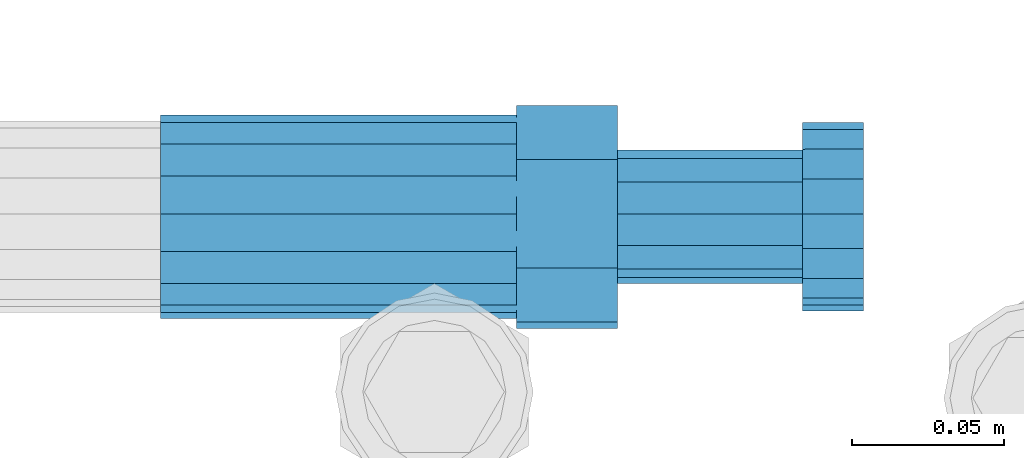
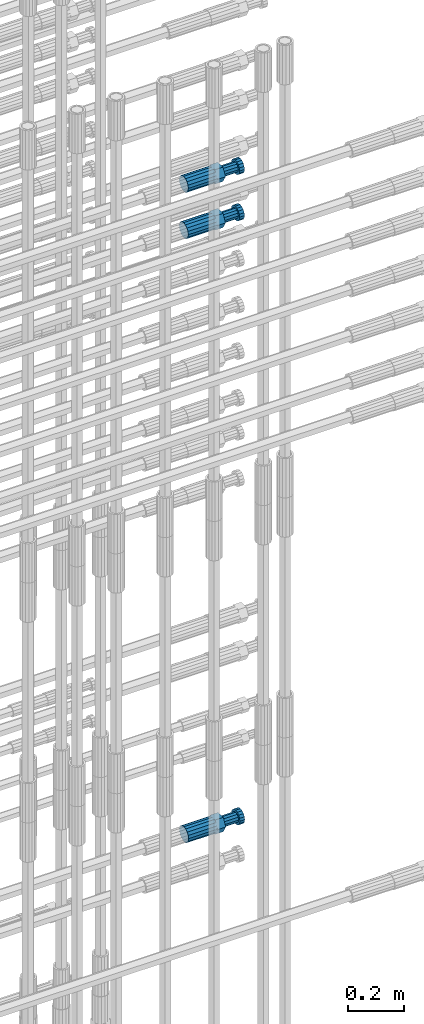
# One storey, part 99 of 119: 3 beams.
"""IFC2X3 building model written with IfcOpenShell, lengths in millimetres."""

from ifc_helpers import new_model, si_unit, frame, origin_with_axes, place, context, subcontext, project, spatial, faceted_brep, material, type_object, element, save


model = new_model("IFC2X3")

# Units and contexts
model_context = context("Model", 3, precision=1e-05, world=origin_with_axes())
body_context = subcontext(model_context, "Body", "Model", "MODEL_VIEW")
ifc_project = project(units=[si_unit("LENGTHUNIT", "METRE", prefix="MILLI"), si_unit("AREAUNIT", "SQUARE_METRE"), si_unit("VOLUMEUNIT", "CUBIC_METRE"), si_unit("MASSUNIT", "GRAM", prefix="KILO"), si_unit("TIMEUNIT", "SECOND"), si_unit("PLANEANGLEUNIT", "RADIAN"), si_unit("SOLIDANGLEUNIT", "STERADIAN"), si_unit("THERMODYNAMICTEMPERATUREUNIT", "DEGREE_CELSIUS"), si_unit("LUMINOUSINTENSITYUNIT", "LUMEN")], contexts=[model_context])

# Site, building, storey
site_placement = place(None, origin_with_axes())
site = spatial("IfcSite", under=ifc_project, at=site_placement, CompositionType="ELEMENT")
building_placement = place(site_placement, origin_with_axes())
building = spatial("IfcBuilding", under=site, at=building_placement, Name="Undefined", CompositionType="ELEMENT")
storey_placement = place(building_placement, origin_with_axes())
storey = spatial("IfcBuildingStorey", under=building, at=storey_placement, Name="Undefined", CompositionType="ELEMENT", Elevation=0.0)

# Beams
ifc_material = material(Name="STEEL/S275")
beam_type = type_object("IfcBeamType", Name="ROD65", PredefinedType="NOTDEFINED")
beam_1_placement = place(storey_placement, frame((2038738.98023304, 6205212.98994599, 19499.269421743), z_axis=(0.0, 0.0, 1.0), x_axis=(1.0, 0.0, 0.0)))
element("IfcBeam", 1, at=beam_1_placement, inside=storey, type_object=beam_type, material=ifc_material, Name="AGB40", ObjectType="ROD65", context=body_context, shape_type="Brep", body=[
    faceted_brep([(116.999999999069, 17.8249999252148, 30.8738056446964), (116.999999998137, 22.0056957420893, 23.632628078838), (116.999999999069, 12.4372115600854, 30.0260848066173), (116.999999999069, 8.17543111252598, 30.8738056446964), (117.000000000931, -17.8250000746921, 30.8738056446964), (150.200000001118, -17.8250000723638, 30.8738056446964), (150.199999999255, 17.8249999275431, 30.8738056446964), (117.000000000931, -8.17543109622784, 30.8738056446964), (117.000000001863, -22.0056959956419, 23.6326278985034), (117.000000000931, -12.4372115437873, 30.0260848066173), (117.000000001863, -35.6500000746455, -2.18278728425503e-10), (150.200000002049, -35.6500000723172, -2.18278728425503e-10), (117.000000001863, -30.8443149488885, 8.32369080289209), (117.000000001863, -30.8443149488885, -8.32369080355784), (117.000000002794, -32.4999999918509, 0.0), (117.000000000931, -17.8250000746921, -30.873805645133), (150.200000001118, -17.8250000723638, -30.873805645133), (117.000000001863, -22.0056959961075, -23.6326278982269), (117.000000000931, -8.17543109389953, -30.873805645133), (117.000000000931, -12.4372115437873, -30.0260848066173), (116.999999999069, 17.8249999252148, -30.873805645133), (150.199999999255, 17.8249999275431, -30.873805645133), (116.999999999069, 8.17543111019768, -30.873805645133), (116.999999999069, 12.4372115600854, -30.0260848066173), (116.999999998137, 22.005695742555, -23.6326280785652), (116.999999998137, 35.6499999251682, -2.18278728425503e-10), (150.199999998324, 35.6499999277294, -2.18278728425503e-10), (116.999999998137, 30.8443150522653, -8.32369036550881), (116.999999997206, 32.5000000081491, 0.0), (116.999999998137, 30.8443150522653, 8.32369036483942), (1.86264514923096e-09, -22.9809703885112, 22.9809703885621), (1.86264514923096e-09, -30.0260848065373, 12.4372115518672), (117.000000001863, -30.0260847983882, 12.4372115518672), (117.000000001863, -22.9809703803621, 22.9809703885621), (-1.86264514923096e-09, 22.9809703885112, -22.9809703885621), (-1.86264514923096e-09, 30.0260848065373, -12.4372115518672), (116.999999998137, 30.0260848146863, -12.4372115518672), (116.999999998137, 22.9809703966603, -22.9809703885621), (1.86264514923096e-09, -30.0260848065373, -12.4372115518672), (1.86264514923096e-09, -22.9809703885112, -22.9809703885621), (117.000000001863, -22.9809703803621, -22.9809703885621), (117.000000001863, -30.0260847983882, -12.4372115518672), (9.31322574615479e-10, -12.4372115519363, 30.0260848066173), (0.0, 0.0, 32.5), (-9.31322574615479e-10, 12.4372115519363, 30.0260848066173), (-1.86264514923096e-09, 22.9809703885112, 22.9809703885621), (-1.86264514923096e-09, 30.0260848065373, 12.4372115518672), (-2.79396772384644e-09, 32.5, 0.0), (-9.31322574615479e-10, 12.4372115519363, -30.0260848066173), (0.0, 0.0, -32.5), (9.31322574615479e-10, -12.4372115519363, -30.0260848066173), (2.79396772384644e-09, -32.5, 0.0), (116.999999998137, 22.9809703966603, 22.9809703885621), (116.999999998137, 30.0260848146863, 12.4372115518672), (117.0, 8.14907252788544e-09, -32.5), (117.0, 8.14907252788544e-09, 32.5), (150.200000000186, -10.5000000959262, 18.1865334791873), (150.199999999255, -9.59262251853943e-08, 20.9999999997126), (150.199999998324, 10.4999999040738, 18.1865334791873), (150.199999997392, 18.1865333835594, 10.4999999997126), (150.199999997392, 20.9999999040738, -2.87400325760245e-10), (150.199999997392, 18.1865333835594, -10.5000000002874), (150.199999998324, 10.4999999040738, -18.1865334797621), (150.199999999255, -9.59262251853943e-08, -21.0000000002874), (150.200000000186, -10.5000000959262, -18.1865334797621), (150.200000000186, -18.1865335754119, -10.5000000002874), (150.200000001118, -21.0000000959262, -2.87400325760245e-10), (150.200000000186, -18.1865335754119, 10.4999999997126), (210.979999999516, 10.4999999082647, 18.1865334791873), (210.979999999516, -9.17352735996246e-08, 20.9999999997126), (210.979999997653, 18.1865333877504, 10.4999999997126), (210.979999997653, 20.9999999082647, -2.87400325760245e-10), (210.979999997653, 18.1865333877504, -10.5000000002874), (210.979999999516, 10.4999999082647, -18.1865334797621), (210.979999999516, -9.17352735996246e-08, -21.0000000002874), (210.979999999516, -10.5000000917353, -18.1865334797621), (210.980000000447, -18.1865335712209, -10.5000000002874), (210.980000001378, -21.0000000917353, -2.87400325760245e-10), (210.980000000447, -18.1865335712209, 10.4999999997126), (210.979999999516, -10.5000000917353, 18.1865334791873), (211.001368402503, -27.7269939335529, -11.4911163272045), (211.003082515672, -21.2238095656503, -21.2238154190527), (231.002518340945, -21.2131946226582, -21.2132004554769), (231.000804228708, -27.7163789905608, -11.4805013636287), (211.001368415542, -11.4911086384673, -27.7269970399575), (231.000804241747, -11.4804936954752, -27.7163820763781), (210.996487061493, -0.0106066407170147, -30.0106107396168), (230.995922887698, 8.30227509140968e-06, -29.999995776041), (210.98918159306, 11.4698940692469, -27.7269970332745), (230.988617419265, 11.4805090120062, -27.7163820696951), (210.980564201251, 21.2025913291145, -21.2238154067054), (230.980000027455, 21.2132062721066, -21.2132004431296), (210.971946807578, 27.7057702087332, -11.4911163110701), (230.971382633783, 27.7163851517253, -11.4805013474943), (210.964641331695, 29.9893806746695, -0.0106149565435771), (230.9640771579, 29.9999956176616, 7.03221303410828e-09), (210.959759964608, 27.7057637346443, 11.4698863966551), (230.959195790812, 27.7163786776364, 11.4805013602345), (210.958045851439, 21.2025793667417, 21.2025854885032), (230.957481677644, 21.2131943097338, 21.2132004520827), (210.959759951569, 11.4698784395587, 27.705767109408), (230.959195776843, 11.4804933823179, 27.7163820729838), (210.964641305618, -0.0106235581915826, 29.9893808090674), (230.964077131823, -8.61519947648048e-06, 29.9999957726432), (210.971946774051, -11.4911242681555, 27.7057671027251), (230.971382599324, -11.4805093251634, 27.7163820663009), (210.98056416586, -21.2238215280231, 21.2025854761559), (230.979999991134, -21.2132065852638, 21.2132004397354), (210.989181559533, -27.7270004076418, 11.4698863805206), (230.988617384806, -27.7163854646496, 11.4805013441), (210.996487035416, -30.0106108735781, -0.0106149740058754), (230.995922861621, -29.999995930586, -1.04300852399319e-08)], [[[0, 1, 2, 3]], [[4, 5, 6, 0, 3, 7]], [[8, 4, 7, 9]], [[10, 11, 5, 4, 8, 12]], [[13, 10, 12, 14]], [[15, 16, 11, 10, 13, 17]], [[18, 15, 17, 19]], [[20, 21, 16, 15, 18, 22]], [[20, 22, 23, 24]], [[25, 26, 21, 20, 24, 27]], [[25, 27, 28, 29]], [[30, 31, 32, 33]], [[34, 35, 36, 37]], [[38, 39, 40, 41]], [[31, 30, 42, 43, 44, 45, 46, 47, 35, 34, 48, 49, 50, 39, 38, 51]], [[46, 45, 52, 53]], [[28, 47, 46, 53, 29]], [[27, 36, 35, 47, 28]], [[24, 37, 36, 27]], [[23, 48, 34, 37, 24]], [[22, 54, 49, 48, 23]], [[18, 54, 22]], [[19, 50, 49, 54, 18]], [[17, 40, 39, 50, 19]], [[13, 41, 40, 17]], [[14, 51, 38, 41, 13]], [[12, 32, 31, 51, 14]], [[8, 33, 32, 12]], [[9, 42, 30, 33, 8]], [[7, 55, 43, 42, 9]], [[3, 55, 7]], [[2, 44, 43, 55, 3]], [[1, 52, 45, 44, 2]], [[29, 53, 52, 1]], [[0, 6, 26, 25, 29, 1]], [[5, 11, 16, 21, 26, 6], [56, 57, 58, 59, 60, 61, 62, 63, 64, 65, 66, 67]], [[68, 58, 57, 69]], [[70, 59, 58, 68]], [[71, 60, 59, 70]], [[72, 61, 60, 71]], [[73, 62, 61, 72]], [[74, 63, 62, 73]], [[75, 64, 63, 74]], [[76, 65, 64, 75]], [[77, 66, 65, 76]], [[78, 67, 66, 77]], [[79, 56, 67, 78]], [[69, 57, 56, 79]], [[80, 81, 82, 83]], [[81, 84, 85, 82]], [[84, 86, 87, 85]], [[86, 88, 89, 87]], [[88, 90, 91, 89]], [[90, 92, 93, 91]], [[92, 94, 95, 93]], [[94, 96, 97, 95]], [[96, 98, 99, 97]], [[98, 100, 101, 99]], [[100, 102, 103, 101]], [[102, 104, 105, 103]], [[104, 106, 107, 105]], [[106, 108, 109, 107]], [[108, 110, 111, 109]], [[82, 85, 87, 89, 91, 93, 95, 97, 99, 101, 103, 105, 107, 109, 111, 83]], [[110, 80, 83, 111]], [[108, 106, 104, 102, 100, 98, 96, 94, 92, 90, 88, 86, 84, 81, 80, 110], [78, 77, 76, 75, 74, 73, 72, 71, 70, 68, 69, 79]]]),
])
beam_2_placement = place(storey_placement, frame((2038739.00023304, 6205214.98994599, 22308.9894219673), z_axis=(0.0, 0.0, 1.0), x_axis=(1.0, 0.0, 0.0)))
element("IfcBeam", 2, at=beam_2_placement, inside=storey, type_object=beam_type, material=ifc_material, Name="AGB40", ObjectType="ROD65", context=body_context, shape_type="Brep", body=[
    faceted_brep([(116.999999999069, 17.8249999252148, 30.8738056446964), (116.999999998137, 22.0056957420893, 23.632628078838), (116.999999999069, 12.4372115600854, 30.0260848066173), (116.999999999069, 8.17543111252598, 30.8738056446964), (117.000000000931, -17.8250000746921, 30.8738056446964), (150.200000001118, -17.8250000723638, 30.8738056446964), (150.199999999255, 17.8249999275431, 30.8738056446964), (117.000000000931, -8.17543109622784, 30.8738056446964), (117.000000001863, -22.0056959956419, 23.6326278985034), (117.000000000931, -12.4372115437873, 30.0260848066173), (117.000000001863, -35.6500000746455, -2.18278728425503e-10), (150.200000002049, -35.6500000723172, -2.18278728425503e-10), (117.000000001863, -30.8443149488885, 8.32369080289209), (117.000000001863, -30.8443149488885, -8.32369080355784), (117.000000002794, -32.4999999918509, 0.0), (117.000000000931, -17.8250000746921, -30.873805645133), (150.200000001118, -17.8250000723638, -30.873805645133), (117.000000001863, -22.0056959961075, -23.6326278982269), (117.000000000931, -8.17543109389953, -30.873805645133), (117.000000000931, -12.4372115437873, -30.0260848066173), (116.999999999069, 17.8249999252148, -30.873805645133), (150.199999999255, 17.8249999275431, -30.873805645133), (116.999999999069, 8.17543111019768, -30.873805645133), (116.999999999069, 12.4372115600854, -30.0260848066173), (116.999999998137, 22.005695742555, -23.6326280785652), (116.999999998137, 35.6499999251682, -2.18278728425503e-10), (150.199999998324, 35.6499999277294, -2.18278728425503e-10), (116.999999998137, 30.8443150522653, -8.32369036550881), (116.999999997206, 32.5000000081491, 0.0), (116.999999998137, 30.8443150522653, 8.32369036483942), (1.86264514923096e-09, -22.9809703885112, 22.9809703885621), (1.86264514923096e-09, -30.0260848065373, 12.4372115518672), (117.000000001863, -30.0260847983882, 12.4372115518672), (117.000000001863, -22.9809703803621, 22.9809703885621), (-1.86264514923096e-09, 22.9809703885112, -22.9809703885621), (-1.86264514923096e-09, 30.0260848065373, -12.4372115518672), (116.999999998137, 30.0260848146863, -12.4372115518672), (116.999999998137, 22.9809703966603, -22.9809703885621), (1.86264514923096e-09, -30.0260848065373, -12.4372115518672), (1.86264514923096e-09, -22.9809703885112, -22.9809703885621), (117.000000001863, -22.9809703803621, -22.9809703885621), (117.000000001863, -30.0260847983882, -12.4372115518672), (9.31322574615479e-10, -12.4372115519363, 30.0260848066173), (0.0, 0.0, 32.5), (-9.31322574615479e-10, 12.4372115519363, 30.0260848066173), (-1.86264514923096e-09, 22.9809703885112, 22.9809703885621), (-1.86264514923096e-09, 30.0260848065373, 12.4372115518672), (-2.79396772384644e-09, 32.5, 0.0), (-9.31322574615479e-10, 12.4372115519363, -30.0260848066173), (0.0, 0.0, -32.5), (9.31322574615479e-10, -12.4372115519363, -30.0260848066173), (2.79396772384644e-09, -32.5, 0.0), (116.999999998137, 22.9809703966603, 22.9809703885621), (116.999999998137, 30.0260848146863, 12.4372115518672), (117.0, 8.14907252788544e-09, -32.5), (117.0, 8.14907252788544e-09, 32.5), (150.200000000186, -10.5000000959262, 18.1865334791873), (150.199999999255, -9.59262251853943e-08, 20.9999999997126), (150.199999998324, 10.4999999040738, 18.1865334791873), (150.199999997392, 18.1865333835594, 10.4999999997126), (150.199999997392, 20.9999999040738, -2.87400325760245e-10), (150.199999997392, 18.1865333835594, -10.5000000002874), (150.199999998324, 10.4999999040738, -18.1865334797621), (150.199999999255, -9.59262251853943e-08, -21.0000000002874), (150.200000000186, -10.5000000959262, -18.1865334797621), (150.200000000186, -18.1865335754119, -10.5000000002874), (150.200000001118, -21.0000000959262, -2.87400325760245e-10), (150.200000000186, -18.1865335754119, 10.4999999997126), (210.979999999516, 10.4999999082647, 18.1865334791873), (210.979999999516, -9.17352735996246e-08, 20.9999999997126), (210.979999997653, 18.1865333877504, 10.4999999997126), (210.979999997653, 20.9999999082647, -2.87400325760245e-10), (210.979999997653, 18.1865333877504, -10.5000000002874), (210.979999999516, 10.4999999082647, -18.1865334797621), (210.979999999516, -9.17352735996246e-08, -21.0000000002874), (210.979999999516, -10.5000000917353, -18.1865334797621), (210.980000000447, -18.1865335712209, -10.5000000002874), (210.980000001378, -21.0000000917353, -2.87400325760245e-10), (210.980000000447, -18.1865335712209, 10.4999999997126), (210.979999999516, -10.5000000917353, 18.1865334791873), (211.001368402503, -27.7269939335529, -11.4911163272045), (211.003082515672, -21.2238095656503, -21.2238154190527), (231.002518340945, -21.2131946226582, -21.2132004554769), (231.000804228708, -27.7163789905608, -11.4805013636287), (211.001368415542, -11.4911086384673, -27.7269970399575), (231.000804241747, -11.4804936954752, -27.7163820763781), (210.996487061493, -0.0106066407170147, -30.0106107396168), (230.995922887698, 8.30227509140968e-06, -29.999995776041), (210.98918159306, 11.4698940692469, -27.7269970332745), (230.988617419265, 11.4805090120062, -27.7163820696951), (210.980564201251, 21.2025913291145, -21.2238154067054), (230.980000027455, 21.2132062721066, -21.2132004431296), (210.971946807578, 27.7057702087332, -11.4911163110701), (230.971382633783, 27.7163851517253, -11.4805013474943), (210.964641331695, 29.9893806746695, -0.0106149565435771), (230.9640771579, 29.9999956176616, 7.03221303410828e-09), (210.959759964608, 27.7057637346443, 11.4698863966551), (230.959195790812, 27.7163786776364, 11.4805013602345), (210.958045851439, 21.2025793667417, 21.2025854885032), (230.957481677644, 21.2131943097338, 21.2132004520827), (210.959759951569, 11.4698784395587, 27.705767109408), (230.959195776843, 11.4804933823179, 27.7163820729838), (210.964641305618, -0.0106235581915826, 29.9893808090674), (230.964077131823, -8.61519947648048e-06, 29.9999957726432), (210.971946774051, -11.4911242681555, 27.7057671027251), (230.971382599324, -11.4805093251634, 27.7163820663009), (210.98056416586, -21.2238215280231, 21.2025854761559), (230.979999991134, -21.2132065852638, 21.2132004397354), (210.989181559533, -27.7270004076418, 11.4698863805206), (230.988617384806, -27.7163854646496, 11.4805013441), (210.996487035416, -30.0106108735781, -0.0106149740058754), (230.995922861621, -29.999995930586, -1.04300852399319e-08)], [[[0, 1, 2, 3]], [[4, 5, 6, 0, 3, 7]], [[8, 4, 7, 9]], [[10, 11, 5, 4, 8, 12]], [[13, 10, 12, 14]], [[15, 16, 11, 10, 13, 17]], [[18, 15, 17, 19]], [[20, 21, 16, 15, 18, 22]], [[20, 22, 23, 24]], [[25, 26, 21, 20, 24, 27]], [[25, 27, 28, 29]], [[30, 31, 32, 33]], [[34, 35, 36, 37]], [[38, 39, 40, 41]], [[31, 30, 42, 43, 44, 45, 46, 47, 35, 34, 48, 49, 50, 39, 38, 51]], [[46, 45, 52, 53]], [[28, 47, 46, 53, 29]], [[27, 36, 35, 47, 28]], [[24, 37, 36, 27]], [[23, 48, 34, 37, 24]], [[22, 54, 49, 48, 23]], [[18, 54, 22]], [[19, 50, 49, 54, 18]], [[17, 40, 39, 50, 19]], [[13, 41, 40, 17]], [[14, 51, 38, 41, 13]], [[12, 32, 31, 51, 14]], [[8, 33, 32, 12]], [[9, 42, 30, 33, 8]], [[7, 55, 43, 42, 9]], [[3, 55, 7]], [[2, 44, 43, 55, 3]], [[1, 52, 45, 44, 2]], [[29, 53, 52, 1]], [[0, 6, 26, 25, 29, 1]], [[5, 11, 16, 21, 26, 6], [56, 57, 58, 59, 60, 61, 62, 63, 64, 65, 66, 67]], [[68, 58, 57, 69]], [[70, 59, 58, 68]], [[71, 60, 59, 70]], [[72, 61, 60, 71]], [[73, 62, 61, 72]], [[74, 63, 62, 73]], [[75, 64, 63, 74]], [[76, 65, 64, 75]], [[77, 66, 65, 76]], [[78, 67, 66, 77]], [[79, 56, 67, 78]], [[69, 57, 56, 79]], [[80, 81, 82, 83]], [[81, 84, 85, 82]], [[84, 86, 87, 85]], [[86, 88, 89, 87]], [[88, 90, 91, 89]], [[90, 92, 93, 91]], [[92, 94, 95, 93]], [[94, 96, 97, 95]], [[96, 98, 99, 97]], [[98, 100, 101, 99]], [[100, 102, 103, 101]], [[102, 104, 105, 103]], [[104, 106, 107, 105]], [[106, 108, 109, 107]], [[108, 110, 111, 109]], [[82, 85, 87, 89, 91, 93, 95, 97, 99, 101, 103, 105, 107, 109, 111, 83]], [[110, 80, 83, 111]], [[108, 106, 104, 102, 100, 98, 96, 94, 92, 90, 88, 86, 84, 81, 80, 110], [78, 77, 76, 75, 74, 73, 72, 71, 70, 68, 69, 79]]]),
])
beam_3_placement = place(storey_placement, frame((2038739.00023304, 6205214.98994599, 22108.9894219673), z_axis=(0.0, 0.0, 1.0), x_axis=(1.0, 0.0, 0.0)))
element("IfcBeam", 3, at=beam_3_placement, inside=storey, type_object=beam_type, material=ifc_material, Name="AGB40", ObjectType="ROD65", context=body_context, shape_type="Brep", body=[
    faceted_brep([(116.999999999069, 17.8249999252148, 30.8738056446964), (116.999999998137, 22.0056957420893, 23.632628078838), (116.999999999069, 12.4372115600854, 30.0260848066173), (116.999999999069, 8.17543111252598, 30.8738056446964), (117.000000000931, -17.8250000746921, 30.8738056446964), (150.200000001118, -17.8250000723638, 30.8738056446964), (150.199999999255, 17.8249999275431, 30.8738056446964), (117.000000000931, -8.17543109622784, 30.8738056446964), (117.000000001863, -22.0056959956419, 23.6326278985034), (117.000000000931, -12.4372115437873, 30.0260848066173), (117.000000001863, -35.6500000746455, -2.18278728425503e-10), (150.200000002049, -35.6500000723172, -2.18278728425503e-10), (117.000000001863, -30.8443149488885, 8.32369080289209), (117.000000001863, -30.8443149488885, -8.32369080355784), (117.000000002794, -32.4999999918509, 0.0), (117.000000000931, -17.8250000746921, -30.873805645133), (150.200000001118, -17.8250000723638, -30.873805645133), (117.000000001863, -22.0056959961075, -23.6326278982269), (117.000000000931, -8.17543109389953, -30.873805645133), (117.000000000931, -12.4372115437873, -30.0260848066173), (116.999999999069, 17.8249999252148, -30.873805645133), (150.199999999255, 17.8249999275431, -30.873805645133), (116.999999999069, 8.17543111019768, -30.873805645133), (116.999999999069, 12.4372115600854, -30.0260848066173), (116.999999998137, 22.005695742555, -23.6326280785652), (116.999999998137, 35.6499999251682, -2.18278728425503e-10), (150.199999998324, 35.6499999277294, -2.18278728425503e-10), (116.999999998137, 30.8443150522653, -8.32369036550881), (116.999999997206, 32.5000000081491, 0.0), (116.999999998137, 30.8443150522653, 8.32369036483942), (1.86264514923096e-09, -22.9809703885112, 22.9809703885621), (1.86264514923096e-09, -30.0260848065373, 12.4372115518672), (117.000000001863, -30.0260847983882, 12.4372115518672), (117.000000001863, -22.9809703803621, 22.9809703885621), (-1.86264514923096e-09, 22.9809703885112, -22.9809703885621), (-1.86264514923096e-09, 30.0260848065373, -12.4372115518672), (116.999999998137, 30.0260848146863, -12.4372115518672), (116.999999998137, 22.9809703966603, -22.9809703885621), (1.86264514923096e-09, -30.0260848065373, -12.4372115518672), (1.86264514923096e-09, -22.9809703885112, -22.9809703885621), (117.000000001863, -22.9809703803621, -22.9809703885621), (117.000000001863, -30.0260847983882, -12.4372115518672), (9.31322574615479e-10, -12.4372115519363, 30.0260848066173), (0.0, 0.0, 32.5), (-9.31322574615479e-10, 12.4372115519363, 30.0260848066173), (-1.86264514923096e-09, 22.9809703885112, 22.9809703885621), (-1.86264514923096e-09, 30.0260848065373, 12.4372115518672), (-2.79396772384644e-09, 32.5, 0.0), (-9.31322574615479e-10, 12.4372115519363, -30.0260848066173), (0.0, 0.0, -32.5), (9.31322574615479e-10, -12.4372115519363, -30.0260848066173), (2.79396772384644e-09, -32.5, 0.0), (116.999999998137, 22.9809703966603, 22.9809703885621), (116.999999998137, 30.0260848146863, 12.4372115518672), (117.0, 8.14907252788544e-09, -32.5), (117.0, 8.14907252788544e-09, 32.5), (150.200000000186, -10.5000000959262, 18.1865334791873), (150.199999999255, -9.59262251853943e-08, 20.9999999997126), (150.199999998324, 10.4999999040738, 18.1865334791873), (150.199999997392, 18.1865333835594, 10.4999999997126), (150.199999997392, 20.9999999040738, -2.87400325760245e-10), (150.199999997392, 18.1865333835594, -10.5000000002874), (150.199999998324, 10.4999999040738, -18.1865334797621), (150.199999999255, -9.59262251853943e-08, -21.0000000002874), (150.200000000186, -10.5000000959262, -18.1865334797621), (150.200000000186, -18.1865335754119, -10.5000000002874), (150.200000001118, -21.0000000959262, -2.87400325760245e-10), (150.200000000186, -18.1865335754119, 10.4999999997126), (210.979999999516, 10.4999999082647, 18.1865334791873), (210.979999999516, -9.17352735996246e-08, 20.9999999997126), (210.979999997653, 18.1865333877504, 10.4999999997126), (210.979999997653, 20.9999999082647, -2.87400325760245e-10), (210.979999997653, 18.1865333877504, -10.5000000002874), (210.979999999516, 10.4999999082647, -18.1865334797621), (210.979999999516, -9.17352735996246e-08, -21.0000000002874), (210.979999999516, -10.5000000917353, -18.1865334797621), (210.980000000447, -18.1865335712209, -10.5000000002874), (210.980000001378, -21.0000000917353, -2.87400325760245e-10), (210.980000000447, -18.1865335712209, 10.4999999997126), (210.979999999516, -10.5000000917353, 18.1865334791873), (211.001368402503, -27.7269939335529, -11.4911163272045), (211.003082515672, -21.2238095656503, -21.2238154190527), (231.002518340945, -21.2131946226582, -21.2132004554769), (231.000804228708, -27.7163789905608, -11.4805013636287), (211.001368415542, -11.4911086384673, -27.7269970399575), (231.000804241747, -11.4804936954752, -27.7163820763781), (210.996487061493, -0.0106066407170147, -30.0106107396168), (230.995922887698, 8.30227509140968e-06, -29.999995776041), (210.98918159306, 11.4698940692469, -27.7269970332745), (230.988617419265, 11.4805090120062, -27.7163820696951), (210.980564201251, 21.2025913291145, -21.2238154067054), (230.980000027455, 21.2132062721066, -21.2132004431296), (210.971946807578, 27.7057702087332, -11.4911163110701), (230.971382633783, 27.7163851517253, -11.4805013474943), (210.964641331695, 29.9893806746695, -0.0106149565435771), (230.9640771579, 29.9999956176616, 7.03221303410828e-09), (210.959759964608, 27.7057637346443, 11.4698863966551), (230.959195790812, 27.7163786776364, 11.4805013602345), (210.958045851439, 21.2025793667417, 21.2025854885032), (230.957481677644, 21.2131943097338, 21.2132004520827), (210.959759951569, 11.4698784395587, 27.705767109408), (230.959195776843, 11.4804933823179, 27.7163820729838), (210.964641305618, -0.0106235581915826, 29.9893808090674), (230.964077131823, -8.61519947648048e-06, 29.9999957726432), (210.971946774051, -11.4911242681555, 27.7057671027251), (230.971382599324, -11.4805093251634, 27.7163820663009), (210.98056416586, -21.2238215280231, 21.2025854761559), (230.979999991134, -21.2132065852638, 21.2132004397354), (210.989181559533, -27.7270004076418, 11.4698863805206), (230.988617384806, -27.7163854646496, 11.4805013441), (210.996487035416, -30.0106108735781, -0.0106149740058754), (230.995922861621, -29.999995930586, -1.04300852399319e-08)], [[[0, 1, 2, 3]], [[4, 5, 6, 0, 3, 7]], [[8, 4, 7, 9]], [[10, 11, 5, 4, 8, 12]], [[13, 10, 12, 14]], [[15, 16, 11, 10, 13, 17]], [[18, 15, 17, 19]], [[20, 21, 16, 15, 18, 22]], [[20, 22, 23, 24]], [[25, 26, 21, 20, 24, 27]], [[25, 27, 28, 29]], [[30, 31, 32, 33]], [[34, 35, 36, 37]], [[38, 39, 40, 41]], [[31, 30, 42, 43, 44, 45, 46, 47, 35, 34, 48, 49, 50, 39, 38, 51]], [[46, 45, 52, 53]], [[28, 47, 46, 53, 29]], [[27, 36, 35, 47, 28]], [[24, 37, 36, 27]], [[23, 48, 34, 37, 24]], [[22, 54, 49, 48, 23]], [[18, 54, 22]], [[19, 50, 49, 54, 18]], [[17, 40, 39, 50, 19]], [[13, 41, 40, 17]], [[14, 51, 38, 41, 13]], [[12, 32, 31, 51, 14]], [[8, 33, 32, 12]], [[9, 42, 30, 33, 8]], [[7, 55, 43, 42, 9]], [[3, 55, 7]], [[2, 44, 43, 55, 3]], [[1, 52, 45, 44, 2]], [[29, 53, 52, 1]], [[0, 6, 26, 25, 29, 1]], [[5, 11, 16, 21, 26, 6], [56, 57, 58, 59, 60, 61, 62, 63, 64, 65, 66, 67]], [[68, 58, 57, 69]], [[70, 59, 58, 68]], [[71, 60, 59, 70]], [[72, 61, 60, 71]], [[73, 62, 61, 72]], [[74, 63, 62, 73]], [[75, 64, 63, 74]], [[76, 65, 64, 75]], [[77, 66, 65, 76]], [[78, 67, 66, 77]], [[79, 56, 67, 78]], [[69, 57, 56, 79]], [[80, 81, 82, 83]], [[81, 84, 85, 82]], [[84, 86, 87, 85]], [[86, 88, 89, 87]], [[88, 90, 91, 89]], [[90, 92, 93, 91]], [[92, 94, 95, 93]], [[94, 96, 97, 95]], [[96, 98, 99, 97]], [[98, 100, 101, 99]], [[100, 102, 103, 101]], [[102, 104, 105, 103]], [[104, 106, 107, 105]], [[106, 108, 109, 107]], [[108, 110, 111, 109]], [[82, 85, 87, 89, 91, 93, 95, 97, 99, 101, 103, 105, 107, 109, 111, 83]], [[110, 80, 83, 111]], [[108, 106, 104, 102, 100, 98, 96, 94, 92, 90, 88, 86, 84, 81, 80, 110], [78, 77, 76, 75, 74, 73, 72, 71, 70, 68, 69, 79]]]),
])

save(model, "model.ifc")
